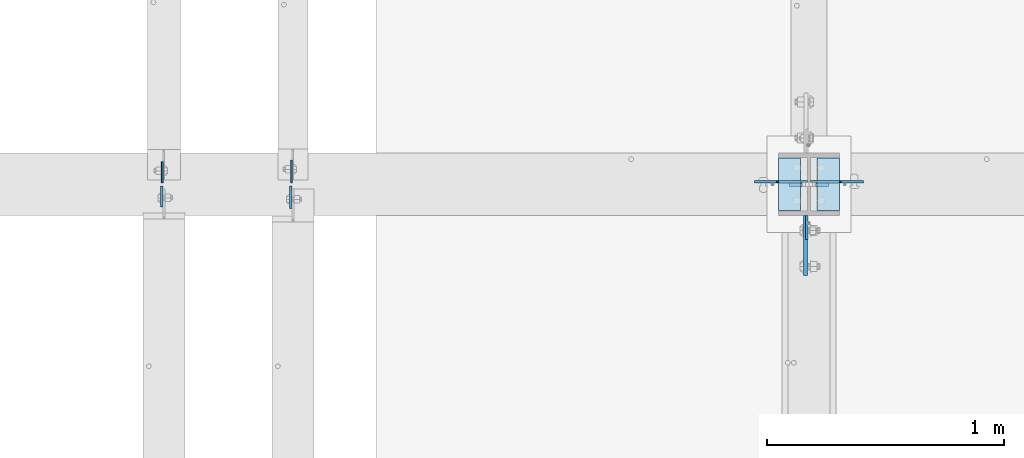
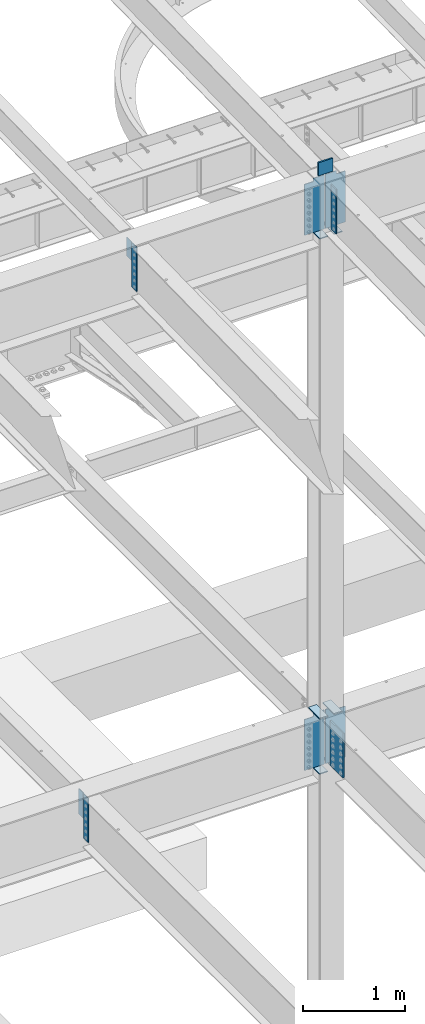
# One storey, part 1551 of 1763: 17 plates, 3 elements without a shape of their own.
"""IFC2X3 building model written with IfcOpenShell, lengths in millimetres."""

from ifc_helpers import new_model, si_unit, frame, origin_with_axes, place, context, subcontext, project, spatial, faceted_brep, material, type_object, element, aggregate, save


model = new_model("IFC2X3")

# Units and contexts
model_context = context("Model", 3, precision=1e-05, world=origin_with_axes())
body_context = subcontext(model_context, "Body", "Model", "MODEL_VIEW")
ifc_project = project(units=[si_unit("LENGTHUNIT", "METRE", prefix="MILLI"), si_unit("AREAUNIT", "SQUARE_METRE"), si_unit("VOLUMEUNIT", "CUBIC_METRE"), si_unit("MASSUNIT", "GRAM", prefix="KILO"), si_unit("TIMEUNIT", "SECOND"), si_unit("PLANEANGLEUNIT", "RADIAN"), si_unit("SOLIDANGLEUNIT", "STERADIAN"), si_unit("THERMODYNAMICTEMPERATUREUNIT", "DEGREE_CELSIUS"), si_unit("LUMINOUSINTENSITYUNIT", "LUMEN")], contexts=[model_context])

# Site, building, storey
site_placement = place(None, origin_with_axes())
site = spatial("IfcSite", under=ifc_project, at=site_placement, CompositionType="ELEMENT")
building_placement = place(site_placement, origin_with_axes())
building = spatial("IfcBuilding", under=site, at=building_placement, Name="Undefined", CompositionType="ELEMENT")
storey_placement = place(building_placement, origin_with_axes())
storey = spatial("IfcBuildingStorey", under=building, at=storey_placement, Name="Undefined", CompositionType="ELEMENT", Elevation=0.0)

# Assembly, plate
assembly_1_placement = place(storey_placement, origin_with_axes())
assembly_1 = element("IfcElementAssembly", 1, at=assembly_1_placement, inside=storey, Name="BEAM", AssemblyPlace="NOTDEFINED", PredefinedType="RIGID_FRAME")
ifc_material_1 = material(Name="STEEL/A36")
plate_type_1 = type_object("IfcPlateType", PredefinedType="NOTDEFINED")
plate_1_placement = place(assembly_1_placement, frame((-63780.1072736983, 44811.9499999732, 11545.0579569989), z_axis=(0.0, 1.0, 0.0), x_axis=(0.0, 0.0, -1.0)))
plate_1 = element("IfcPlate", 2, at=plate_1_placement, type_object=plate_type_1, material=ifc_material_1, Name="PLATE", context=body_context, shape_type="Brep", body=[
    faceted_brep([(1.81898940354586e-12, -3.17500000000291, 0.0), (0.0, -3.17499999999927, 95.25), (0.0, 3.17499999999927, 95.25), (-1.81898940354586e-12, 3.17499999997381, 0.0), (228.600006103516, -3.17500000000291, 95.25), (228.600006103516, 3.17500000000291, 95.25), (228.600006103516, -3.17500000001019, -7.27595761418343e-12), (228.600006103516, 3.17499999999563, -7.27595761418343e-12)], [[[0, 1, 2, 3]], [[1, 4, 5, 2]], [[4, 6, 7, 5]], [[6, 0, 3, 7]], [[5, 7, 3, 2]], [[6, 4, 1, 0]]]),
])

assembly_2_placement = place(storey_placement, origin_with_axes())
assembly_2 = element("IfcElementAssembly", 3, at=assembly_2_placement, inside=storey, Name="BEAM", AssemblyPlace="NOTDEFINED", PredefinedType="RIGID_FRAME")
plate_type_2 = type_object("IfcPlateType", PredefinedType="NOTDEFINED")
plate_2_placement = place(assembly_2_placement, frame((-64328.1122736983, 44799.25, 5143.5), z_axis=(0.0, -1.0, 0.0), x_axis=(0.0, 0.0, -1.0)))
plate_2 = element("IfcPlate", 4, at=plate_2_placement, type_object=plate_type_2, material=ifc_material_1, Name="PLATE", context=body_context, shape_type="Brep", body=[
    faceted_brep([(0.0, -4.76249999999982, 0.0), (0.0, -4.76250000000073, 88.9000015258789), (0.0, 4.76250000000073, 88.9000015258789), (0.0, 4.76249999999982, 0.0), (533.400024414062, -4.76250000000073, 88.9000015258789), (533.400024414062, 4.76250000000073, 88.9000015258789), (533.400024414062, -4.76250000000073, 0.0), (533.400024414062, 4.76250000000073, 0.0)], [[[0, 1, 2, 3]], [[1, 4, 5, 2]], [[4, 6, 7, 5]], [[6, 0, 3, 7]], [[5, 7, 3, 2]], [[6, 4, 1, 0]]]),
])

# Assembly, plates
assembly_3_placement = place(storey_placement, origin_with_axes())
assembly_3 = element("IfcElementAssembly", 5, at=assembly_3_placement, inside=storey, Name="COLUMN", AssemblyPlace="NOTDEFINED", PredefinedType="RIGID_FRAME")
ifc_material_2 = material(Name="STEEL/A572-50")
plate_type_3 = type_object("IfcPlateType", PredefinedType="NOTDEFINED")
plate_3_placement = place(assembly_3_placement, frame((-61511.8872721725, 44805.5999999732, 11760.2588348652), z_axis=(0.0, 0.0, -1.0), x_axis=(-1.0, 0.0, 0.0)))
plate_3 = element("IfcPlate", 6, at=plate_3_placement, type_object=plate_type_3, material=ifc_material_2, Name="PLATE", context=body_context, shape_type="Brep", body=[
    faceted_brep([(7.27595761418343e-12, 9.52500000000146, 155.574990844727), (-1.45519152283669e-11, 7.27595761418343e-12, 165.099990844727), (165.099990844727, 0.0, 165.099990844727), (165.099990844727, 9.52500000000146, 155.574990844727), (-3.63797880709171e-11, -9.5249999999869, 155.574990844727), (165.099990844727, -9.52500000000146, 155.574990844727), (0.0, 9.52500000000146, 0.0), (0.0, -9.52500000000146, 0.0), (165.099990844727, -9.52500000000146, 0.0), (165.099990844727, 9.52500000000146, 0.0)], [[[0, 1, 2, 3]], [[1, 4, 5, 2]], [[6, 7, 4, 1, 0]], [[5, 8, 9, 3, 2]], [[8, 7, 6, 9]], [[9, 6, 0, 3]], [[7, 8, 5, 4]]]),
])
plate_type_4 = type_object("IfcPlateType", PredefinedType="NOTDEFINED")
plate_4_placement = place(assembly_3_placement, frame((-61603.9622736983, 44673.8374999996, 11553.994807839), z_axis=(0.0, -1.0, 0.0), x_axis=(0.0, 0.0, -1.0)))
plate_4 = element("IfcPlate", 7, at=plate_4_placement, type_object=plate_type_4, material=ifc_material_1, Name="PLATE", context=body_context, shape_type="Brep", body=[
    faceted_brep([(0.0, -4.76249999999982, 0.0), (1.45519152283669e-11, -4.76250000000448, 101.60001373291), (0.0, 4.76250000000243, 101.60001373291), (0.0, 4.76249999999982, 0.0), (533.400024414062, -4.76249999999709, 101.599998474121), (533.400024414062, 4.76249999999709, 101.599998474121), (533.400024414062, -4.76250000000073, 0.0), (533.400024414062, 4.76250000000073, 0.0)], [[[0, 1, 2, 3]], [[1, 4, 5, 2]], [[4, 6, 7, 5]], [[6, 0, 3, 7]], [[5, 7, 3, 2]], [[6, 4, 1, 0]]]),
])
plate_type_5 = type_object("IfcPlateType", PredefinedType="NOTDEFINED")
plate_5_placement = place(assembly_3_placement, frame((-61465.8497736983, 44694.475, 10928.4088287617), z_axis=(0.0, 1.0, 0.0), x_axis=(-1.0, 0.0, 0.0)))
plate_5 = element("IfcPlate", 8, at=plate_5_placement, type_object=plate_type_5, material=ifc_material_1, Name="PLATE", context=body_context, shape_type="Brep", body=[
    faceted_brep([(0.0, -6.34999999999491, 1.45519152283669e-11), (0.0, -6.35000000000036, 222.25), (0.0, 6.35000000000036, 222.25), (0.0, 6.34999999999491, -2.91038304567337e-11), (93.6624984741211, -6.35000000000036, 222.25), (93.6624984741211, 6.35000000000036, 222.25), (93.6624984741211, -6.35000000000036, 0.0), (93.6624984741211, 6.35000000000036, 0.0)], [[[0, 1, 2, 3]], [[1, 4, 5, 2]], [[4, 6, 7, 5]], [[6, 0, 3, 7]], [[5, 7, 3, 2]], [[6, 4, 1, 0]]]),
])
plate_6_placement = place(assembly_3_placement, frame((-61723.0247736983, 44916.725, 10928.4088287617), z_axis=(0.0, -1.0, 0.0), x_axis=(1.0, 0.0, 0.0)))
plate_6 = element("IfcPlate", 9, at=plate_6_placement, type_object=plate_type_5, material=ifc_material_1, Name="PLATE", context=body_context, shape_type="Brep", body=[
    faceted_brep([(0.0, -6.34999999999491, 1.45519152283669e-11), (0.0, -6.35000000000036, 222.25), (0.0, 6.35000000000036, 222.25), (0.0, 6.34999999999491, -2.91038304567337e-11), (93.6624984741211, -6.35000000000036, 222.25), (93.6624984741211, 6.35000000000036, 222.25), (93.6624984741211, -6.35000000000036, 0.0), (93.6624984741211, 6.35000000000036, 0.0)], [[[0, 1, 2, 3]], [[1, 4, 5, 2]], [[4, 6, 7, 5]], [[6, 0, 3, 7]], [[5, 7, 3, 2]], [[6, 4, 1, 0]]]),
])
plate_7_placement = place(assembly_3_placement, frame((-61723.0247736983, 44916.725, 4527.54998779297), z_axis=(0.0, -1.0, 0.0), x_axis=(1.0, 0.0, 0.0)))
plate_7 = element("IfcPlate", 10, at=plate_7_placement, type_object=plate_type_5, material=ifc_material_1, Name="PLATE", context=body_context, shape_type="Brep", body=[
    faceted_brep([(0.0, -6.34999999999491, 1.45519152283669e-11), (0.0, -6.35000000000036, 222.25), (0.0, 6.35000000000036, 222.25), (0.0, 6.34999999999491, -2.91038304567337e-11), (93.6624984741211, -6.35000000000036, 222.25), (93.6624984741211, 6.35000000000036, 222.25), (93.6624984741211, -6.35000000000036, 0.0), (93.6624984741211, 6.35000000000036, 0.0)], [[[0, 1, 2, 3]], [[1, 4, 5, 2]], [[4, 6, 7, 5]], [[6, 0, 3, 7]], [[5, 7, 3, 2]], [[6, 4, 1, 0]]]),
])
plate_8_placement = place(assembly_3_placement, frame((-61723.0247736983, 44916.725, 5187.95), z_axis=(0.0, -1.0, 0.0), x_axis=(1.0, 0.0, 0.0)))
plate_8 = element("IfcPlate", 11, at=plate_8_placement, type_object=plate_type_5, material=ifc_material_1, Name="PLATE", context=body_context, shape_type="Brep", body=[
    faceted_brep([(0.0, -6.34999999999491, 1.45519152283669e-11), (0.0, -6.35000000000036, 222.25), (0.0, 6.35000000000036, 222.25), (0.0, 6.34999999999491, -2.91038304567337e-11), (93.6624984741211, -6.35000000000036, 222.25), (93.6624984741211, 6.35000000000036, 222.25), (93.6624984741211, -6.35000000000036, 0.0), (93.6624984741211, 6.35000000000036, 0.0)], [[[0, 1, 2, 3]], [[1, 4, 5, 2]], [[4, 6, 7, 5]], [[6, 0, 3, 7]], [[5, 7, 3, 2]], [[6, 4, 1, 0]]]),
])
plate_9_placement = place(assembly_3_placement, frame((-61465.8497736983, 44694.475, 4527.54998779297), z_axis=(0.0, 1.0, 0.0), x_axis=(-1.0, 0.0, 0.0)))
plate_9 = element("IfcPlate", 12, at=plate_9_placement, type_object=plate_type_5, material=ifc_material_1, Name="PLATE", context=body_context, shape_type="Brep", body=[
    faceted_brep([(0.0, -6.34999999999491, 1.45519152283669e-11), (0.0, -6.35000000000036, 222.25), (0.0, 6.35000000000036, 222.25), (0.0, 6.34999999999491, -2.91038304567337e-11), (93.6624984741211, -6.35000000000036, 222.25), (93.6624984741211, 6.35000000000036, 222.25), (93.6624984741211, -6.35000000000036, 0.0), (93.6624984741211, 6.35000000000036, 0.0)], [[[0, 1, 2, 3]], [[1, 4, 5, 2]], [[4, 6, 7, 5]], [[6, 0, 3, 7]], [[5, 7, 3, 2]], [[6, 4, 1, 0]]]),
])
plate_10_placement = place(assembly_3_placement, frame((-61465.8497736983, 44694.475, 5187.95), z_axis=(0.0, 1.0, 0.0), x_axis=(-1.0, 0.0, 0.0)))
plate_10 = element("IfcPlate", 13, at=plate_10_placement, type_object=plate_type_5, material=ifc_material_1, Name="PLATE", context=body_context, shape_type="Brep", body=[
    faceted_brep([(0.0, -6.34999999999491, 1.45519152283669e-11), (0.0, -6.35000000000036, 222.25), (0.0, 6.35000000000036, 222.25), (0.0, 6.34999999999491, -2.91038304567337e-11), (93.6624984741211, -6.35000000000036, 222.25), (93.6624984741211, 6.35000000000036, 222.25), (93.6624984741211, -6.35000000000036, 0.0), (93.6624984741211, 6.35000000000036, 0.0)], [[[0, 1, 2, 3]], [[1, 4, 5, 2]], [[4, 6, 7, 5]], [[6, 0, 3, 7]], [[5, 7, 3, 2]], [[6, 4, 1, 0]]]),
])

# Plate
plate_type_6 = type_object("IfcPlateType", PredefinedType="NOTDEFINED")
plate_11_placement = place(assembly_1_placement, frame((-63783.2822736984, 44799.2499999732, 11545.606050315), z_axis=(0.0, -1.0, 0.0), x_axis=(0.0, 0.0, -1.0)))
plate_11 = element("IfcPlate", 14, at=plate_11_placement, type_object=plate_type_6, material=ifc_material_1, Name="PLATE", context=body_context, shape_type="Brep", body=[
    faceted_brep([(0.0, -4.76249999999982, 0.0), (0.0, -4.76249999999709, 95.25), (0.0, 4.76249999999709, 95.25), (0.0, 4.76249999999982, 0.0), (533.400024414062, -4.76249999999709, 95.25), (533.400024414062, 4.76249999999709, 95.25), (533.400024414062, -4.76250000000073, 0.0), (533.400024414062, 4.76250000000073, 0.0)], [[[0, 1, 2, 3]], [[1, 4, 5, 2]], [[4, 6, 7, 5]], [[6, 0, 3, 7]], [[5, 7, 3, 2]], [[6, 4, 1, 0]]]),
])

aggregate(assembly_1, [plate_1, plate_11])

plate_type_7 = type_object("IfcPlateType", PredefinedType="NOTDEFINED")
plate_12_placement = place(assembly_2_placement, frame((-64325.7312736984, 44811.95, 5143.5), z_axis=(0.0, 1.0, 0.0), x_axis=(0.0, 0.0, -1.0)))
plate_12 = element("IfcPlate", 15, at=plate_12_placement, type_object=plate_type_7, material=ifc_material_1, Name="PLATE", context=body_context, shape_type="Brep", body=[
    faceted_brep([(0.0, -3.96900000000096, 0.0), (0.0, -3.96899999999732, 88.9000015258789), (0.0, 3.96899999999732, 88.9000015258789), (0.0, 3.96900000000096, 0.0), (304.799987792969, -3.96899999999732, 88.9000015258789), (304.799987792969, 3.96899999999732, 88.9000015258789), (304.799987792969, -3.96900000000096, -3.63797880709171e-11), (304.799987792969, 3.96900000000096, -3.63797880709171e-11)], [[[0, 1, 2, 3]], [[1, 4, 5, 2]], [[4, 6, 7, 5]], [[6, 0, 3, 7]], [[5, 7, 3, 2]], [[6, 4, 1, 0]]]),
])

aggregate(assembly_2, [plate_2, plate_12])

plate_type_8 = type_object("IfcPlateType", PredefinedType="NOTDEFINED")
plate_13_placement = place(assembly_3_placement, frame((-61608.7247736983, 44673.8375, 5143.5), z_axis=(0.0, -1.0, 0.0), x_axis=(0.0, 0.0, -1.0)))
plate_13 = element("IfcPlate", 16, at=plate_13_placement, type_object=plate_type_8, material=ifc_material_2, Name="PLATE", context=body_context, shape_type="Brep", body=[
    faceted_brep([(-7.27595761418343e-12, -7.9375, 0.0), (0.0, -7.9375, 254.0), (0.0, 7.9375, 254.0), (-7.27595761418343e-12, 7.9375, 0.0), (533.400024414062, -7.9375, 254.0), (533.400024414062, 7.9375, 254.0), (533.400024414062, -7.9375, 0.0), (533.400024414062, 7.9375, 0.0)], [[[0, 1, 2, 3]], [[1, 4, 5, 2]], [[4, 6, 7, 5]], [[6, 0, 3, 7]], [[5, 7, 3, 2]], [[6, 4, 1, 0]]]),
])

plate_type_9 = type_object("IfcPlateType", PredefinedType="NOTDEFINED")
plate_14_placement = place(assembly_3_placement, frame((-61588.0872736983, 44816.7124999732, 11582.4588409687), z_axis=(1.0, 0.0, 0.0), x_axis=(0.0, 0.0, -1.0)))
plate_14 = element("IfcPlate", 17, at=plate_14_placement, type_object=plate_type_9, material=ifc_material_1, Name="PLATE", context=body_context, shape_type="Brep", body=[
    faceted_brep([(25.4000001907334, -4.76250000000073, 122.237503051758), (25.4000001907334, 4.76250000000073, 122.237503051758), (-2.5465851649642e-11, 4.76250000019581, 122.237500000236), (-3.45607986673713e-11, -4.76249999983202, 122.23750000025), (30.2600797087798, -4.76250000000073, 123.204232974349), (30.2600797087798, 4.76250000000073, 123.204232974349), (34.3802561769335, -4.76250000000073, 125.957246874823), (34.3802561769335, 4.76250000000073, 125.957246874823), (37.133270077411, -4.76250000000073, 130.077423342977), (37.133270077411, 4.76250000000073, 130.077423342977), (38.0999999999985, -4.76250000000073, 134.937502861023), (38.0999999999985, 4.76250000000073, 134.937502861023), (38.0999999999985, -4.76250000000073, 223.837493896484), (38.0999999999985, 4.76250000000073, 223.837493896484), (647.700012207031, -4.76250000000073, 0.0), (0.0, -4.76249999999982, 0.0), (0.0, 4.76249999999982, 0.0), (647.700012207031, 4.76250000000073, 0.0), (647.700012207031, -4.76250000000073, 223.837493896484), (647.700012207031, 4.76250000000073, 223.837493896484)], [[[0, 1, 2, 3]], [[4, 5, 1, 0]], [[6, 7, 5, 4]], [[8, 9, 7, 6]], [[10, 11, 9, 8]], [[12, 13, 11, 10]], [[14, 15, 16, 17]], [[18, 14, 17, 19]], [[8, 6, 4, 0, 3, 15, 14, 18, 12, 10]], [[16, 15, 3, 2]], [[19, 17, 16, 2, 1, 5, 7, 9, 11, 13]], [[18, 19, 13, 12]]]),
])

plate_15_placement = place(assembly_3_placement, frame((-61600.7872736983, 44816.7124999732, 11582.4588409687), z_axis=(-1.0, 0.0, 0.0), x_axis=(0.0, 0.0, -1.0)))
plate_15 = element("IfcPlate", 18, at=plate_15_placement, type_object=plate_type_9, material=ifc_material_1, Name="PLATE", context=body_context, shape_type="Brep", body=[
    faceted_brep([(25.4000001907334, -4.76250000000073, 122.237503051758), (25.4000001907334, 4.76250000000073, 122.237503051758), (-2.5465851649642e-11, 4.76250000019581, 122.237500000236), (-3.45607986673713e-11, -4.76249999983202, 122.23750000025), (30.2600797087798, -4.76250000000073, 123.204232974349), (30.2600797087798, 4.76250000000073, 123.204232974349), (34.3802561769335, -4.76250000000073, 125.957246874823), (34.3802561769335, 4.76250000000073, 125.957246874823), (37.133270077411, -4.76250000000073, 130.077423342977), (37.133270077411, 4.76250000000073, 130.077423342977), (38.0999999999985, -4.76250000000073, 134.937502861023), (38.0999999999985, 4.76250000000073, 134.937502861023), (38.0999999999985, -4.76250000000073, 223.837493896484), (38.0999999999985, 4.76250000000073, 223.837493896484), (647.700012207031, -4.76250000000073, 0.0), (0.0, -4.76249999999982, 0.0), (0.0, 4.76249999999982, 0.0), (647.700012207031, 4.76250000000073, 0.0), (647.700012207031, -4.76250000000073, 223.837493896484), (647.700012207031, 4.76250000000073, 223.837493896484)], [[[0, 1, 2, 3]], [[4, 5, 1, 0]], [[6, 7, 5, 4]], [[8, 9, 7, 6]], [[10, 11, 9, 8]], [[12, 13, 11, 10]], [[14, 15, 16, 17]], [[18, 14, 17, 19]], [[8, 6, 4, 0, 3, 15, 14, 18, 12, 10]], [[16, 15, 3, 2]], [[19, 17, 16, 2, 1, 5, 7, 9, 11, 13]], [[18, 19, 13, 12]]]),
])

plate_16_placement = place(assembly_3_placement, frame((-61600.7872736983, 44816.7125, 5181.6), z_axis=(-1.0, 0.0, 0.0), x_axis=(0.0, 0.0, -1.0)))
plate_16 = element("IfcPlate", 19, at=plate_16_placement, type_object=plate_type_9, material=ifc_material_1, Name="PLATE", context=body_context, shape_type="Brep", body=[
    faceted_brep([(25.4000001907334, -4.76250000000073, 122.237503051758), (25.4000001907334, 4.76250000000073, 122.237503051758), (-2.5465851649642e-11, 4.76250000019581, 122.237500000236), (-3.45607986673713e-11, -4.76249999983202, 122.23750000025), (30.2600797087798, -4.76250000000073, 123.204232974349), (30.2600797087798, 4.76250000000073, 123.204232974349), (34.3802561769335, -4.76250000000073, 125.957246874823), (34.3802561769335, 4.76250000000073, 125.957246874823), (37.133270077411, -4.76250000000073, 130.077423342977), (37.133270077411, 4.76250000000073, 130.077423342977), (38.0999999999985, -4.76250000000073, 134.937502861023), (38.0999999999985, 4.76250000000073, 134.937502861023), (38.0999999999985, -4.76250000000073, 223.837493896484), (38.0999999999985, 4.76250000000073, 223.837493896484), (647.700012207031, -4.76250000000073, 0.0), (0.0, -4.76249999999982, 0.0), (0.0, 4.76249999999982, 0.0), (647.700012207031, 4.76250000000073, 0.0), (647.700012207031, -4.76250000000073, 223.837493896484), (647.700012207031, 4.76250000000073, 223.837493896484)], [[[0, 1, 2, 3]], [[4, 5, 1, 0]], [[6, 7, 5, 4]], [[8, 9, 7, 6]], [[10, 11, 9, 8]], [[12, 13, 11, 10]], [[14, 15, 16, 17]], [[18, 14, 17, 19]], [[8, 6, 4, 0, 3, 15, 14, 18, 12, 10]], [[16, 15, 3, 2]], [[19, 17, 16, 2, 1, 5, 7, 9, 11, 13]], [[18, 19, 13, 12]]]),
])

plate_17_placement = place(assembly_3_placement, frame((-61588.0872736983, 44816.7125, 5181.6), z_axis=(1.0, 0.0, 0.0), x_axis=(0.0, 0.0, -1.0)))
plate_17 = element("IfcPlate", 20, at=plate_17_placement, type_object=plate_type_9, material=ifc_material_1, Name="PLATE", context=body_context, shape_type="Brep", body=[
    faceted_brep([(25.4000001907334, -4.76250000000073, 122.237503051758), (25.4000001907334, 4.76250000000073, 122.237503051758), (-2.5465851649642e-11, 4.76250000019581, 122.237500000236), (-3.45607986673713e-11, -4.76249999983202, 122.23750000025), (30.2600797087798, -4.76250000000073, 123.204232974349), (30.2600797087798, 4.76250000000073, 123.204232974349), (34.3802561769335, -4.76250000000073, 125.957246874823), (34.3802561769335, 4.76250000000073, 125.957246874823), (37.133270077411, -4.76250000000073, 130.077423342977), (37.133270077411, 4.76250000000073, 130.077423342977), (38.0999999999985, -4.76250000000073, 134.937502861023), (38.0999999999985, 4.76250000000073, 134.937502861023), (38.0999999999985, -4.76250000000073, 223.837493896484), (38.0999999999985, 4.76250000000073, 223.837493896484), (647.700012207031, -4.76250000000073, 0.0), (0.0, -4.76249999999982, 0.0), (0.0, 4.76249999999982, 0.0), (647.700012207031, 4.76250000000073, 0.0), (647.700012207031, -4.76250000000073, 223.837493896484), (647.700012207031, 4.76250000000073, 223.837493896484)], [[[0, 1, 2, 3]], [[4, 5, 1, 0]], [[6, 7, 5, 4]], [[8, 9, 7, 6]], [[10, 11, 9, 8]], [[12, 13, 11, 10]], [[14, 15, 16, 17]], [[18, 14, 17, 19]], [[8, 6, 4, 0, 3, 15, 14, 18, 12, 10]], [[16, 15, 3, 2]], [[19, 17, 16, 2, 1, 5, 7, 9, 11, 13]], [[18, 19, 13, 12]]]),
])

aggregate(assembly_3, [plate_3, plate_5, plate_14, plate_6, plate_15, plate_4, plate_7, plate_8, plate_16, plate_9, plate_10, plate_17, plate_13])

save(model, "model.ifc")
